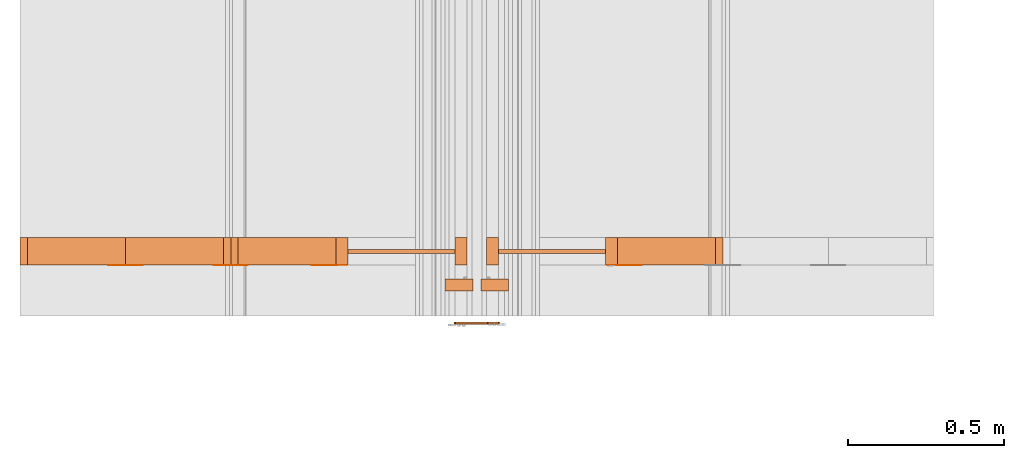
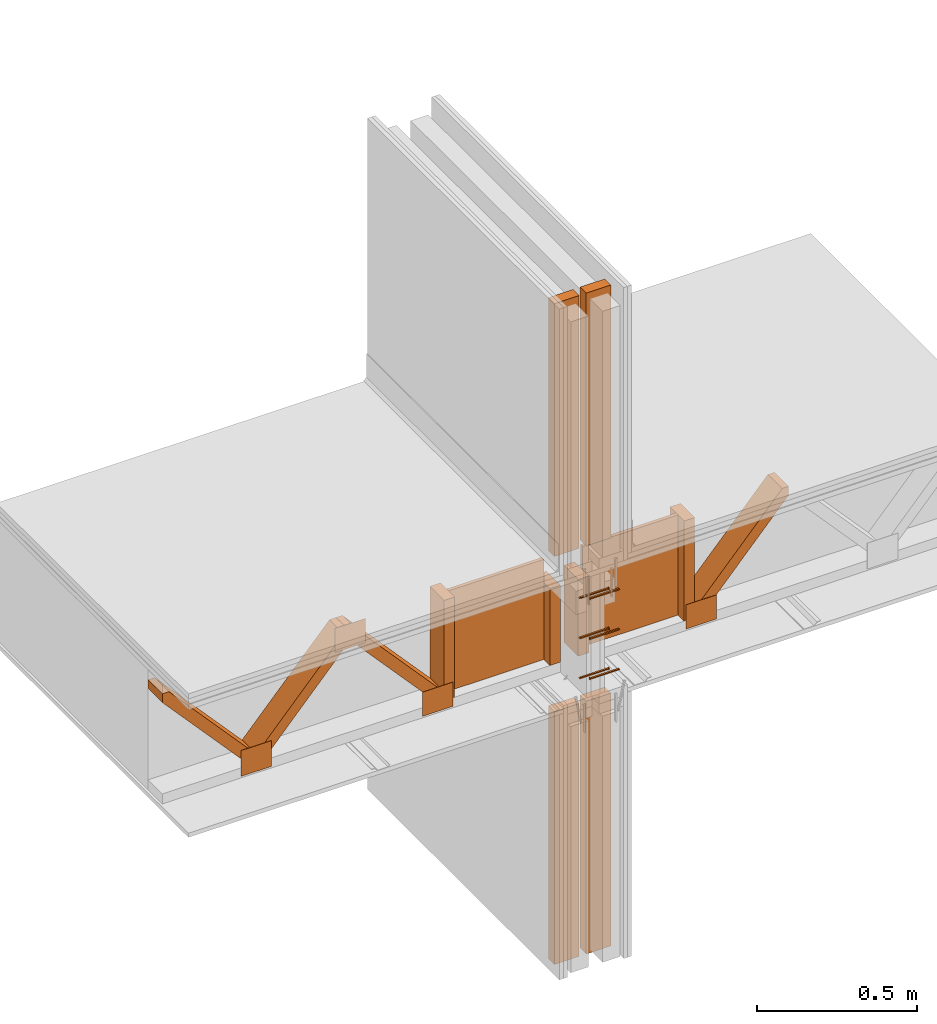
# One storey, part 6 of 22: 25 proxies.
"""IFC2X3 building model written with IfcOpenShell, lengths in feet."""

from ifc_helpers import new_model, entity, si_unit, converted_unit, frame, frame_2d, origin_with_axes, place, context, subcontext, project, spatial, polyline, rectangle, outline, extrude, source, transform, mapped, type_object, type_shapes, element, save


model = new_model("IFC2X3")

# Units and contexts
model_context = context("Model", 3, precision=1e-05)
plan_context = context("Plan", 2, precision=1e-05, world=frame_2d((0.0, 0.0, 0.0), x_axis=(1.0, 0.0, 0.0)))
body_context = subcontext(model_context, "Body", "Model", "MODEL_VIEW")
ifc_project = project(units=[converted_unit("VOLUMEUNIT", "cubic foot", entity("IfcReal", 0.0283168467116885), si_unit("VOLUMEUNIT", "CUBIC_METRE"), dimensions=[3, 0, 0, 0, 0, 0, 0]), converted_unit("AREAUNIT", "square foot", entity("IfcReal", 0.09290304), si_unit("AREAUNIT", "SQUARE_METRE"), dimensions=[2, 0, 0, 0, 0, 0, 0]), converted_unit("LENGTHUNIT", "foot", entity("IfcReal", 0.3048), si_unit("LENGTHUNIT", "METRE"), dimensions=[1, 0, 0, 0, 0, 0, 0])], contexts=[model_context, plan_context])

# Site, building, storey
site_placement = place(None, origin_with_axes())
site = spatial("IfcSite", under=ifc_project, at=site_placement, CompositionType="ELEMENT")
building_placement = place(site_placement, origin_with_axes())
building = spatial("IfcBuilding", under=site, at=building_placement, Name="Building", CompositionType="ELEMENT")
storey_placement = place(building_placement, origin_with_axes())
storey = spatial("IfcBuildingStorey", under=building, at=storey_placement, Name="Storey", CompositionType="ELEMENT")

# Proxies
building_element_proxy_type = type_object("IfcBuildingElementProxyType", PredefinedType="NOTDEFINED")
shared_shape = source(origin_with_axes(), body_context, "Body", "SweptSolid", [
    extrude(outline(polyline([(0.111323627313291, 1.94594512519944e-12), (0.11174819796417, -0.00686187885598991), (0.11861007758404, -0.0064373005663101), (0.116911782758442, 0.0210102125660093), (0.110049903138572, 0.0205856342763295), (0.110474473789452, 0.0137237561842197), (-0.222222659531541, -0.00686187503658959), (-0.235521823676239, -0.0145729112358192), (-0.22137349378562, -0.0205856312208093), (0.111323627313291, 1.94594512519944e-12)])), frame((0.111111134212474, -9.54850080601499e-11, -8.48755740522435e-09), z_axis=(-7.22965936006403e-08, 7.6731799896184e-14, -1.0), x_axis=(-0.998091220855713, -0.0617568828165531, 7.2158591990501e-08)), (7.24534032769952e-08, -3.00251157270282e-10, -0.999999940395355), 0.0199999997321789),
])
type_shapes(building_element_proxy_type, [shared_shape])
for number, where, z_axis, x_axis in (
    (1, (1575.94986162161, 1.80479774637798, -60.3012838388678), (-3.25841369885893e-07, 1.0, -4.37113882867379e-08), (-1.0, -3.25841369885893e-07, 1.62920656521237e-07)),
    (2, (1575.94986162161, 1.80479794193128, -60.8012807650829), (-3.25841369885893e-07, 1.0, 7.54979012640433e-08), (-1.0, -3.25841369885893e-07, 4.37113882867379e-08)),
    (3, (1575.94986162161, 1.80479774637798, -61.301277691298), (-3.89414395840504e-07, 1.0, -1.62920684942947e-07), (-1.0, -3.89414367418794e-07, 4.37114060503063e-08)),
    (4, (1575.73559778569, 1.80479774637798, -61.3512767581489), (-1.19209303761636e-07, 1.0, -4.37113882867379e-08), (1.0, 1.19209303761636e-07, 4.37113918394516e-08)),
    (5, (1575.73559778569, 1.80479774637798, -60.3512829057188), (-1.19209303761636e-07, 1.0, -4.37113882867379e-08), (1.0, 1.19209303761636e-07, 4.37113918394516e-08)),
    (6, (1575.73559778569, 1.80479774637798, -60.8512798319338), (-1.19209289550781e-07, 1.0, -4.37113882867379e-08), (1.0, 1.19209289550781e-07, -5.96046341172496e-08)),
):
    element("IfcBuildingElementProxy", number, at=place(storey_placement, frame(where, z_axis=z_axis, x_axis=x_axis)), inside=storey, type_object=building_element_proxy_type, context=body_context, shape_type="MappedRepresentation", body=[
        mapped(shared_shape, transform((0.0, 0.0, 0.0), x_axis=(1.0, 0.0, 0.0), y_axis=(0.0, 1.0, 0.0), z_axis=(0.0, 0.0, 1.0), scale=1.0)),
    ])
for number, where, z_axis, x_axis, name in (
    (7, (1575.46766786751, -0.783451722832177, -62.9761525652227), (0.0, 0.0, 1.0), (1.0, 0.0, 0.0), "Plane"),
    (8, (1575.09260603136, -0.783451722832177, -62.9761525652227), (0.0, 0.0, 1.0), (1.0, 0.0, 0.0), "Plane"),
    (9, (1575.46766786751, -0.783451722832177, -57.8829747798249), (0.0, 0.0, 1.0), (1.0, 0.0, 0.0), "Plane"),
    (10, (1575.09260603136, -0.783451722832177, -57.8829747798249), (0.0, 0.0, 1.0), (1.0, 0.0, 0.0), "Plane"),
):
    element("IfcBuildingElementProxy", number, at=place(storey_placement, frame(where, z_axis=z_axis, x_axis=x_axis)), inside=storey, Name=name, context=body_context, shape_type="SweptSolid", body=[
        extrude(rectangle(XDim=0.125000015272121, YDim=0.291666767700657, at=frame_2d((0.0, 0.0, 0.0))), frame((0.56250001306296, 2.99930689841744, -2.07206552110006), z_axis=(0.0, 0.0, -1.0), x_axis=(0.0, 1.0, 0.0)), (0.0, 0.0, -1.0), 3.1556764266711),
    ])
proxy_1_placement = place(storey_placement, frame((1570.73213672388, 2.42488121423196, -61.8508731912127), z_axis=(0.0, 0.0, 1.0), x_axis=(1.0, 0.0, 0.0)))
element("IfcBuildingElementProxy", 11, at=proxy_1_placement, inside=storey, Name="Generic Models 855:Generic Models 1", context=body_context, shape_type="SweptSolid", body=[
    extrude(rectangle(XDim=0.124999233345449, YDim=0.291669311091376, at=frame_2d((0.0, 0.0, 0.0))), frame((3.69392433191535, 0.145834848636717, 0.333333109307477), z_axis=(-1.56443593368749e-06, 0.0, -1.0), x_axis=(0.999999940395355, 0.0, -1.56443593368749e-06)), (-7.30079079858115e-07, 0.0, -1.0), 1.25000238621637),
])
proxy_2_placement = place(storey_placement, frame((1571.84080188981, 2.42488121423196, -61.9758708583401), z_axis=(0.0, 0.0, 1.0), x_axis=(1.0, 0.0, 0.0)))
element("IfcBuildingElementProxy", 12, at=proxy_2_placement, inside=storey, Name="Generic Models 855:Generic Models 1", context=body_context, shape_type="SweptSolid", body=[
    extrude(outline(polyline([(-0.784177323338866, -0.0648422464923909), (0.754565469861969, -0.0648422709365529), (0.835367211988905, 0.00826408231039373), (0.784177372227191, 0.0648422220482288), (-0.754565469861969, 0.0648421487157426), (-0.835367114212256, -0.00826408231039373), (-0.784177323338866, -0.0648422464923909)])), frame((0.859770405636685, 2.21605038198473e-07, 1.08333436522897), z_axis=(-5.63137181330831e-09, -1.0, -3.61699434847651e-08), x_axis=(-0.670913577079773, 3.07118845910281e-08, -0.741535544395447)), (3.07119094600239e-08, 2.00910594827519e-08, -1.0), 0.291666664589754),
])
proxy_3_placement = place(storey_placement, frame((1571.84080188981, 2.42488121423196, -61.9758708583401), z_axis=(0.0, 0.0, 1.0), x_axis=(1.0, 0.0, 0.0)))
element("IfcBuildingElementProxy", 13, at=proxy_3_placement, inside=storey, Name="Generic Models 855:Generic Models 1", context=body_context, shape_type="SweptSolid", body=[
    extrude(outline(polyline([(-0.624998797738333, -0.554331018542993), (-0.516033567625081, -0.554331018542993), (0.624998944403305, 0.478032379951377), (0.624998944403305, 0.554331018542993), (0.516033518736757, 0.554331018542993), (-0.624998797738333, -0.478032379951377), (-0.624998797738333, -0.554331018542993)])), frame((1.96849032649844, 2.46049223573641e-07, 1.08333387634573), z_axis=(-7.55355833437221e-10, -1.0, 1.20567182904097e-08), x_axis=(0.0, -1.15278186996193e-08, -1.0)), (-1.15278284695819e-08, -7.55356333037582e-10, -1.0), 0.291666664589754),
])
proxy_4_placement = place(storey_placement, frame((1571.88946180769, 2.42211120178693, -61.6217035008228), z_axis=(0.0, 0.0, 1.0), x_axis=(1.0, 0.0, 0.0)))
element("IfcBuildingElementProxy", 14, at=proxy_4_placement, inside=storey, Name="Generic Models 852:Generic Models 1", context=body_context, shape_type="SweptSolid", body=[
    extrude(rectangle(XDim=0.360929982303518, YDim=0.00277022707595213, at=frame_2d((0.0, 0.0, 0.0))), frame((2.39778886942726, 0.00138511354766121, 0.0), z_axis=(0.0, 0.0, -1.0), x_axis=(-1.0, 0.0, 0.0)), (0.0, 0.0, -1.0), 0.301264184929359),
])
proxy_5_placement = place(storey_placement, frame((1571.96585587629, 2.42211120178693, -61.6217035008228), z_axis=(0.0, 0.0, 1.0), x_axis=(1.0, 0.0, 0.0)))
element("IfcBuildingElementProxy", 15, at=proxy_5_placement, inside=storey, Name="Generic Models 852:Generic Models 1", context=body_context, shape_type="SweptSolid", body=[
    extrude(rectangle(XDim=0.360930148950862, YDim=0.00277022707595213, at=frame_2d((0.0, 0.0, 0.0))), frame((0.180465076363149, 0.00138511354766121, 0.0), z_axis=(0.0, 0.0, -1.0), x_axis=(1.0, 0.0, 0.0)), (0.0, 0.0, -1.0), 0.322097519461289),
])
proxy_6_placement = place(storey_placement, frame((1571.96585587629, 2.42211120178693, -61.9550389567698), z_axis=(0.0, 0.0, 1.0), x_axis=(1.0, 0.0, 0.0)))
element("IfcBuildingElementProxy", 16, at=proxy_6_placement, inside=storey, Name="Generic Models 852:Generic Models 1", context=body_context, shape_type="SweptSolid", body=[
    extrude(rectangle(XDim=0.360930176725411, YDim=0.00277022707595213, at=frame_2d((0.0, 0.0, 0.0))), frame((1.28912702789457, 0.00138511354766121, 1.4904025071875), z_axis=(0.0, 0.0, -1.0), x_axis=(-1.0, 0.0, 0.0)), (0.0, 0.0, -1.0), 0.301264218204712),
])
proxy_7_placement = place(storey_placement, frame((1569.62347155794, 2.42488121423196, -61.9758708583401), z_axis=(0.0, 0.0, 1.0), x_axis=(1.0, 0.0, 0.0)))
element("IfcBuildingElementProxy", 17, at=proxy_7_placement, inside=storey, Name="Generic Models 855:Generic Models 1", context=body_context, shape_type="SweptSolid", body=[
    extrude(outline(polyline([(-0.624998797738333, -0.554331018542993), (-0.516033567625081, -0.554331018542993), (0.624998944403305, 0.478032379951377), (0.624998944403305, 0.554331018542993), (0.516033518736757, 0.554331018542993), (-0.624998797738333, -0.478032379951377), (-0.624998797738333, -0.554331018542993)])), frame((1.96849032649844, 2.46049223573641e-07, 1.08333387634573), z_axis=(-7.55355833437221e-10, -1.0, 1.20567182904097e-08), x_axis=(0.0, -1.15278186996193e-08, -1.0)), (-1.15278284695819e-08, -7.55356333037582e-10, -1.0), 0.291666664589754),
])
proxy_8_placement = place(storey_placement, frame((1571.98217597221, 2.42488121423196, -61.8508731912127), z_axis=(0.0, 0.0, 1.0), x_axis=(1.0, 0.0, 0.0)))
element("IfcBuildingElementProxy", 18, at=proxy_8_placement, inside=storey, Name="Generic Models 855:Generic Models 1", context=body_context, shape_type="SweptSolid", body=[
    extrude(rectangle(XDim=0.124999233345449, YDim=0.291669311091376, at=frame_2d((0.0, 0.0, 0.0))), frame((3.69392433191535, 0.145834848636717, 0.333333109307477), z_axis=(-1.56443593368749e-06, 0.0, -1.0), x_axis=(0.999999940395355, 0.0, -1.56443593368749e-06)), (-4.76898435408657e-07, 0.0, -1.0), 0.958999603993231),
])
proxy_9_placement = place(storey_placement, frame((1576.62919812941, 2.54988416129836, -59.5704714457194), z_axis=(0.0, 0.0, 1.0), x_axis=(-1.62920684942947e-07, 1.0, 0.0)))
element("IfcBuildingElementProxy", 19, at=proxy_9_placement, inside=storey, Name="Plane", context=body_context, shape_type="SweptSolid", body=[
    extrude(rectangle(XDim=0.0416666640300221, YDim=1.12508459659183, at=frame_2d((0.0, 0.0, 0.0))), frame((0.0208332826654742, 1.57809906744269, -1.94706785397267), z_axis=(0.0, 0.0, -1.0), x_axis=(-1.0, 0.0, 0.0)), (1.46664405065167e-08, 0.0, -0.999999940395355), 1.25000482420942),
])
proxy_10_placement = place(storey_placement, frame((1578.43051620043, 2.42488140978525, -60.2675360331698), z_axis=(0.0, 0.0, 1.0), x_axis=(1.0, 0.0, 0.0)))
element("IfcBuildingElementProxy", 20, at=proxy_10_placement, inside=storey, Name="Generic Models 855:Generic Models 1", context=body_context, shape_type="SweptSolid", body=[
    extrude(outline(polyline([(-0.624998944403305, -0.554331018542993), (-0.516033714290053, -0.554331018542993), (0.624998846626657, 0.478032379951377), (0.624998846626657, 0.554331018542993), (0.516033420960108, 0.554331018542993), (-0.624998944403305, -0.478032379951377), (-0.624998944403305, -0.554331018542993)])), frame((-0.554349009446272, 5.04959154105692e-08, -0.625001095489567), z_axis=(-7.55358386950178e-10, 1.0, -1.20567129613391e-08), x_axis=(0.0, -1.15278186996193e-08, -1.0)), (-1.15278204759761e-08, -7.5535849797248e-10, 1.0), 0.291666664589754),
])
proxy_11_placement = place(storey_placement, frame((1579.70328343509, 2.42488121423196, -61.8508731912127), z_axis=(0.0, 0.0, 1.0), x_axis=(1.0, 0.0, 0.0)))
element("IfcBuildingElementProxy", 21, at=proxy_11_placement, inside=storey, Name="Generic Models 855:Generic Models 1", context=body_context, shape_type="SweptSolid", body=[
    extrude(rectangle(XDim=0.291669311091376, YDim=0.124999233345449, at=frame_2d((0.0, 0.0, 0.0))), frame((-3.69392550523513, 0.145834848636717, 1.29233273308421), z_axis=(1.56443593368749e-06, 0.0, -1.0), x_axis=(0.0, 1.0, 0.0)), (0.0, -2.71882129254664e-07, 1.0), 0.958999603993157),
])
proxy_12_placement = place(storey_placement, frame((1575.05626127789, 2.54988416129836, -59.5704714457194), z_axis=(0.0, 0.0, 1.0), x_axis=(1.0, 0.0, 0.0)))
element("IfcBuildingElementProxy", 22, at=proxy_12_placement, inside=storey, Name="Plane", context=body_context, shape_type="SweptSolid", body=[
    extrude(rectangle(XDim=1.12508459659184, YDim=0.0416666640300221, at=frame_2d((0.0, 0.0, 0.0))), frame((1.57809906744269, 0.0208330260017725, -1.94706785397267), z_axis=(0.0, 0.0, -1.0), x_axis=(-1.0, 1.62948808224428e-07, 0.0)), (2.71576072741198e-09, -1.42779192913167e-08, -1.0), 1.25000476005176),
])
proxy_13_placement = place(storey_placement, frame((1577.1968971713, 2.42488140978525, -60.2675360331698), z_axis=(0.0, 0.0, 1.0), x_axis=(1.0, 0.0, 0.0)))
element("IfcBuildingElementProxy", 23, at=proxy_13_placement, inside=storey, Name="Generic Models 855:Generic Models 1", context=body_context, shape_type="SweptSolid", body=[
    extrude(rectangle(XDim=0.291669311091376, YDim=0.124999233345449, at=frame_2d((0.0, 0.0, 0.0))), frame((0.0625012046474171, 0.145834653083421, -1.25000463539534), z_axis=(1.56443593368749e-06, 0.0, -1.0), x_axis=(0.0, -1.0, 0.0)), (0.0, -6.01322824422823e-07, -1.0), 1.25000289947842),
])
for number, where, z_axis, x_axis, name in (
    (24, (1575.00039248329, 2.42211120178693, -61.6217035008228), (0.0, 0.0, 1.0), (1.0, 0.0, 0.0), "Generic Models 852:Generic Models 1"),
    (25, (1571.88946180769, 2.42211120178693, -61.6217035008228), (0.0, 0.0, 1.0), (1.0, 0.0, 0.0), "Generic Models 852:Generic Models 1"),
):
    element("IfcBuildingElementProxy", number, at=place(storey_placement, frame(where, z_axis=z_axis, x_axis=x_axis)), inside=storey, Name=name, context=body_context, shape_type="SweptSolid", body=[
        extrude(rectangle(XDim=0.360929982303518, YDim=0.00277022707595213, at=frame_2d((0.0, 0.0, 0.0))), frame((2.39778886942726, 0.00138511354766121, 0.0), z_axis=(0.0, 0.0, -1.0), x_axis=(1.0, 0.0, 0.0)), (0.0, 0.0, -1.0), 0.301264184929359),
    ])

save(model, "model.ifc")
